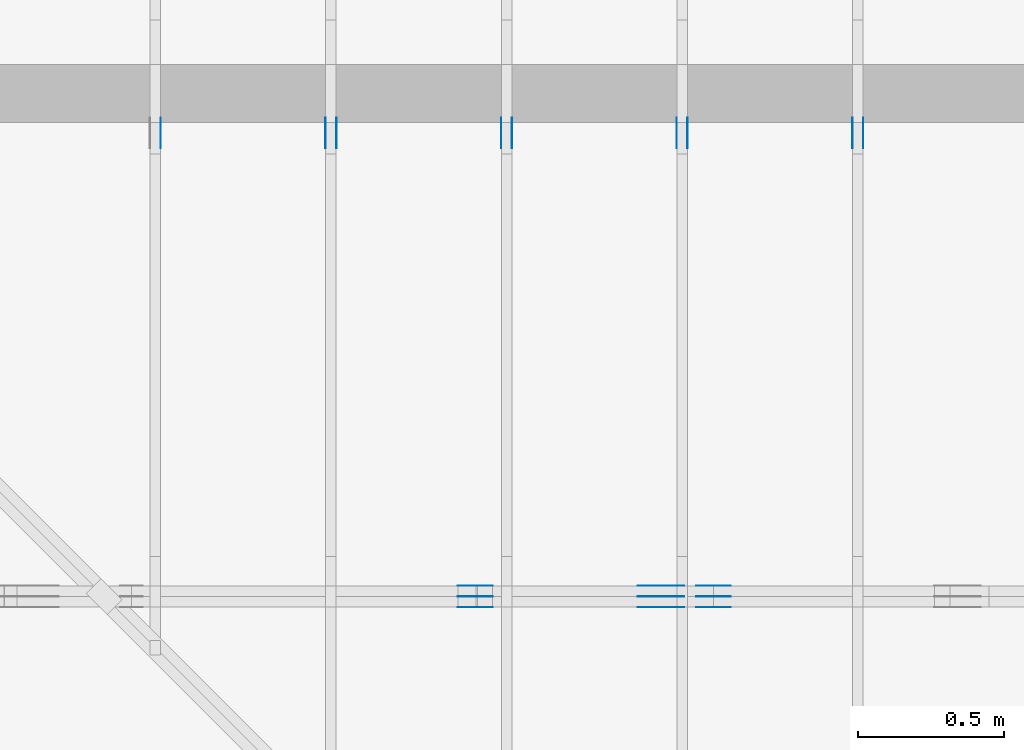
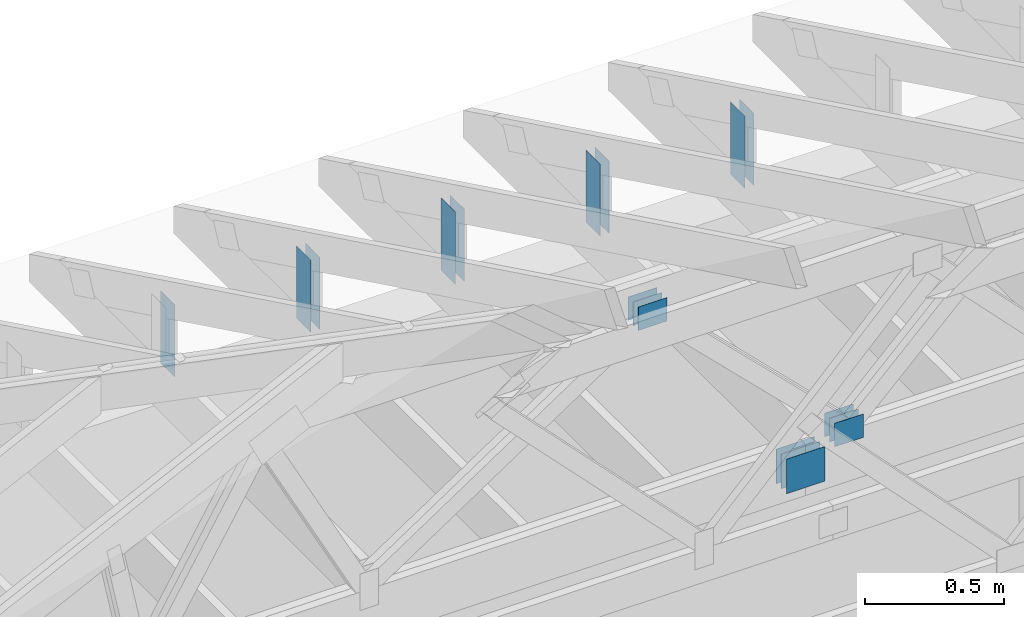
# One storey, part 110 of 159: 21 plates, 6 elements without a shape of their own.
"""IFC2X3 building model written with IfcOpenShell, lengths in millimetres."""

from ifc_helpers import new_model, si_unit, frame, origin, origin_with_axes, origin_2d, place, context, project, spatial, faceted_brep, element, aggregate, save


model = new_model("IFC2X3")

# Units and contexts
model_context = context("Model", 3, precision=1e-05, world=origin())
plan_context = context("Plan", 2, precision=1e-05, world=origin_2d())
ifc_project = project(units=[si_unit("LENGTHUNIT", "METRE", prefix="MILLI"), si_unit("AREAUNIT", "SQUARE_METRE"), si_unit("VOLUMEUNIT", "CUBIC_METRE"), si_unit("SOLIDANGLEUNIT", "STERADIAN"), si_unit("PLANEANGLEUNIT", "RADIAN"), si_unit("MASSUNIT", "GRAM"), si_unit("TIMEUNIT", "SECOND"), si_unit("THERMODYNAMICTEMPERATUREUNIT", "DEGREE_CELSIUS"), si_unit("LUMINOUSINTENSITYUNIT", "LUMEN")], contexts=[model_context, plan_context])

# Site, building, storey
site_placement = place(None, origin_with_axes())
site = spatial("IfcSite", under=ifc_project, at=site_placement, CompositionType="ELEMENT")
building_placement = place(site_placement, origin_with_axes())
building = spatial("IfcBuilding", under=site, at=building_placement, Name="Plan 1", CompositionType="ELEMENT")
storey_placement = place(building_placement, origin_with_axes())
storey = spatial("IfcBuildingStorey", under=building, at=storey_placement, Name="Etasje 1", CompositionType="ELEMENT", Elevation=0.0)

# Assembly, plates
assembly_1_placement = place(storey_placement, frame((19200.01266310149, 11417.999978540158, 0.0), z_axis=(1.2246063538223773e-16, 1.0, 6.123031769111886e-17), x_axis=(-1.0, 1.2246063538223773e-16, 0.0)))
assembly_1 = element("IfcElementAssembly", 1, at=assembly_1_placement, inside=storey, Name="V9 (1)", AssemblyPlace="FACTORY", PredefinedType="TRUSS")
plate_1_placement = place(assembly_1_placement, frame((5473.56888521173, 1069.3871058922014, 0.0), z_axis=(0.0, 0.0, 1.0), x_axis=(-1.0, 1.2246063538223773e-16, 0.0)))
plate_1 = element("IfcPlate", 2, at=plate_1_placement, Name="GNT100S 103x119", context=model_context, shape_type="Brep", body=[
    faceted_brep([(119.00003755548005, 103.00002093126386, 1.0), (3.755548004846787e-05, 103.00002093126386, 1.0), (3.755548004846787e-05, 2.093126386171207e-05, 1.0), (119.00003755548005, 2.093126386171207e-05, 1.0), (3.755548004846787e-05, 103.00002093126386, 4.5990679488203275e-21), (119.00003755548005, 103.00002093126386, 1.4572820209554237e-14), (119.00003755548005, 2.093126386171207e-05, 1.4572820209554237e-14), (3.755548004846787e-05, 2.093126386171207e-05, 4.5990679488203275e-21), (119.0, -2.1859223415729434e-14, 1.3384471942262577e-30), (119.0, -2.1797993098038315e-14, 1.0), (1.1247455413666031e-32, 6.123031769111886e-17, 1.0), (0.0, 0.0, 0.0), (119.0, 103.0, 0.0), (119.0, 103.0, 1.0), (119.0, 0.0, 1.0), (119.0, 0.0, 0.0), (0.0, 103.0, 0.0), (-3.7491518045553436e-33, 103.0, 1.0), (119.0, 102.99999999999999, 1.0), (119.0, 102.99999999999999, -7.888609052210118e-31), (0.0, 0.0, 0.0), (6.123031769111886e-17, -7.498303609110687e-33, 1.0), (1.2674675762061605e-14, 103.0, 1.0), (1.2613445444370486e-14, 103.0, -7.723252717384008e-31)], [[[0, 1, 2, 3]], [[4, 5, 6, 7]], [[8, 9, 10, 11]], [[12, 13, 14, 15]], [[16, 17, 18, 19]], [[20, 21, 22, 23]]]),
])
plate_2_placement = place(assembly_1_placement, frame((5473.56888521173, 1069.3871058922014, -37.0), z_axis=(0.0, 0.0, 1.0), x_axis=(-1.0, 1.2246063538223773e-16, 0.0)))
plate_2 = element("IfcPlate", 3, at=plate_2_placement, Name="GNT100S 103x119", context=model_context, shape_type="Brep", body=[
    faceted_brep([(119.00003755548005, 103.00002093126386, 1.0), (3.755548004846787e-05, 103.00002093126386, 1.0), (3.755548004846787e-05, 2.093126386171207e-05, 1.0), (119.00003755548005, 2.093126386171207e-05, 1.0), (3.755548004846787e-05, 103.00002093126386, 4.5990679488203275e-21), (119.00003755548005, 103.00002093126386, 1.4572820209554237e-14), (119.00003755548005, 2.093126386171207e-05, 1.4572820209554237e-14), (3.755548004846787e-05, 2.093126386171207e-05, 4.5990679488203275e-21), (119.0, -2.1859223415729434e-14, 1.3384471942262577e-30), (119.0, -2.1797993098038315e-14, 1.0), (1.1247455413666031e-32, 6.123031769111886e-17, 1.0), (0.0, 0.0, 0.0), (119.0, 103.0, 0.0), (119.0, 103.0, 1.0), (119.0, 0.0, 1.0), (119.0, 0.0, 0.0), (0.0, 103.0, 0.0), (-3.7491518045553436e-33, 103.0, 1.0), (119.0, 102.99999999999999, 1.0), (119.0, 102.99999999999999, -7.888609052210118e-31), (0.0, 0.0, 0.0), (6.123031769111886e-17, -7.498303609110687e-33, 1.0), (1.2674675762061605e-14, 103.0, 1.0), (1.2613445444370486e-14, 103.0, -7.723252717384008e-31)], [[[0, 1, 2, 3]], [[4, 5, 6, 7]], [[8, 9, 10, 11]], [[12, 13, 14, 15]], [[16, 17, 18, 19]], [[20, 21, 22, 23]]]),
])
plate_3_placement = place(assembly_1_placement, frame((5473.56888521173, 1069.3871058922014, -36.0), z_axis=(0.0, 0.0, 1.0), x_axis=(-1.0, 1.2246063538223773e-16, 0.0)))
plate_3 = element("IfcPlate", 4, at=plate_3_placement, Name="GNT100S 103x119", context=model_context, shape_type="Brep", body=[
    faceted_brep([(119.00003755548005, 103.00002093126386, 1.0), (3.755548004846787e-05, 103.00002093126386, 1.0), (3.755548004846787e-05, 2.093126386171207e-05, 1.0), (119.00003755548005, 2.093126386171207e-05, 1.0), (3.755548004846787e-05, 103.00002093126386, 4.5990679488203275e-21), (119.00003755548005, 103.00002093126386, 1.4572820209554237e-14), (119.00003755548005, 2.093126386171207e-05, 1.4572820209554237e-14), (3.755548004846787e-05, 2.093126386171207e-05, 4.5990679488203275e-21), (119.0, -2.1859223415729434e-14, 1.3384471942262577e-30), (119.0, -2.1797993098038315e-14, 1.0), (1.1247455413666031e-32, 6.123031769111886e-17, 1.0), (0.0, 0.0, 0.0), (119.0, 103.0, 0.0), (119.0, 103.0, 1.0), (119.0, 0.0, 1.0), (119.0, 0.0, 0.0), (0.0, 103.0, 0.0), (-3.7491518045553436e-33, 103.0, 1.0), (119.0, 102.99999999999999, 1.0), (119.0, 102.99999999999999, -7.888609052210118e-31), (0.0, 0.0, 0.0), (6.123031769111886e-17, -7.498303609110687e-33, 1.0), (1.2674675762061605e-14, 103.0, 1.0), (1.2613445444370486e-14, 103.0, -7.723252717384008e-31)], [[[0, 1, 2, 3]], [[4, 5, 6, 7]], [[8, 9, 10, 11]], [[12, 13, 14, 15]], [[16, 17, 18, 19]], [[20, 21, 22, 23]]]),
])
plate_4_placement = place(assembly_1_placement, frame((5473.56888521173, 1069.3871058922014, -73.0), z_axis=(0.0, 0.0, 1.0), x_axis=(-1.0, 1.2246063538223773e-16, 0.0)))
plate_4 = element("IfcPlate", 5, at=plate_4_placement, Name="GNT100S 103x119", context=model_context, shape_type="Brep", body=[
    faceted_brep([(119.00003755548005, 103.00002093126386, 1.0), (3.755548004846787e-05, 103.00002093126386, 1.0), (3.755548004846787e-05, 2.093126386171207e-05, 1.0), (119.00003755548005, 2.093126386171207e-05, 1.0), (3.755548004846787e-05, 103.00002093126386, 4.5990679488203275e-21), (119.00003755548005, 103.00002093126386, 1.4572820209554237e-14), (119.00003755548005, 2.093126386171207e-05, 1.4572820209554237e-14), (3.755548004846787e-05, 2.093126386171207e-05, 4.5990679488203275e-21), (119.0, -2.1859223415729434e-14, 1.3384471942262577e-30), (119.0, -2.1797993098038315e-14, 1.0), (1.1247455413666031e-32, 6.123031769111886e-17, 1.0), (0.0, 0.0, 0.0), (119.0, 103.0, 0.0), (119.0, 103.0, 1.0), (119.0, 0.0, 1.0), (119.0, 0.0, 0.0), (0.0, 103.0, 0.0), (-3.7491518045553436e-33, 103.0, 1.0), (119.0, 102.99999999999999, 1.0), (119.0, 102.99999999999999, -7.888609052210118e-31), (0.0, 0.0, 0.0), (6.123031769111886e-17, -7.498303609110687e-33, 1.0), (1.2674675762061605e-14, 103.0, 1.0), (1.2613445444370486e-14, 103.0, -7.723252717384008e-31)], [[[0, 1, 2, 3]], [[4, 5, 6, 7]], [[8, 9, 10, 11]], [[12, 13, 14, 15]], [[16, 17, 18, 19]], [[20, 21, 22, 23]]]),
])
plate_5_placement = place(assembly_1_placement, frame((4859.5, 187.50000000000034, 0.0), z_axis=(0.0, 0.0, 1.0), x_axis=(-1.0, 1.2246063538223773e-16, 0.0)))
plate_5 = element("IfcPlate", 6, at=plate_5_placement, Name="GNT100S 152x159", context=model_context, shape_type="Brep", body=[
    faceted_brep([(159.0, 152.00000000000034, 1.0), (0.0, 152.00000000000034, 1.0), (0.0, 3.410605131648481e-13, 1.0), (159.0, 3.410605131648481e-13, 1.0), (0.0, 152.00000000000034, 0.0), (159.0, 152.00000000000034, 1.9471241025775798e-14), (159.0, 3.694822225952521e-13, 1.9471241025775798e-14), (0.0, 3.694822225952521e-13, 0.0), (159.0, -2.92068615386637e-14, 1.788345410772899e-30), (159.0, -2.914563122097258e-14, 1.0), (1.1247455413666031e-32, 6.123031769111886e-17, 1.0), (0.0, 0.0, 0.0), (159.0, 152.0, 0.0), (159.0, 152.0, 1.0), (159.0, 0.0, 1.0), (159.0, 0.0, 0.0), (0.0, 152.0, 0.0), (-3.7491518045553436e-33, 152.0, 1.0), (159.0, 152.0, 1.0), (159.0, 152.0, 0.0), (0.0, 0.0, 0.0), (6.123031769111886e-17, -7.498303609110687e-33, 1.0), (1.8675246895791253e-14, 152.0, 1.0), (1.8614016578100134e-14, 152.0, -1.1397421485848245e-30)], [[[0, 1, 2, 3]], [[4, 5, 6, 7]], [[8, 9, 10, 11]], [[12, 13, 14, 15]], [[16, 17, 18, 19]], [[20, 21, 22, 23]]]),
])
plate_6_placement = place(assembly_1_placement, frame((4859.5, 187.50000000000034, -37.0), z_axis=(0.0, 0.0, 1.0), x_axis=(-1.0, 1.2246063538223773e-16, 0.0)))
plate_6 = element("IfcPlate", 7, at=plate_6_placement, Name="GNT100S 152x159", context=model_context, shape_type="Brep", body=[
    faceted_brep([(159.0, 152.00000000000034, 1.0), (0.0, 152.00000000000034, 1.0), (0.0, 3.410605131648481e-13, 1.0), (159.0, 3.410605131648481e-13, 1.0), (0.0, 152.00000000000034, 0.0), (159.0, 152.00000000000034, 1.9471241025775798e-14), (159.0, 3.694822225952521e-13, 1.9471241025775798e-14), (0.0, 3.694822225952521e-13, 0.0), (159.0, -2.92068615386637e-14, 1.788345410772899e-30), (159.0, -2.914563122097258e-14, 1.0), (1.1247455413666031e-32, 6.123031769111886e-17, 1.0), (0.0, 0.0, 0.0), (159.0, 152.0, 0.0), (159.0, 152.0, 1.0), (159.0, 0.0, 1.0), (159.0, 0.0, 0.0), (0.0, 152.0, 0.0), (-3.7491518045553436e-33, 152.0, 1.0), (159.0, 152.0, 1.0), (159.0, 152.0, 0.0), (0.0, 0.0, 0.0), (6.123031769111886e-17, -7.498303609110687e-33, 1.0), (1.8675246895791253e-14, 152.0, 1.0), (1.8614016578100134e-14, 152.0, -1.1397421485848245e-30)], [[[0, 1, 2, 3]], [[4, 5, 6, 7]], [[8, 9, 10, 11]], [[12, 13, 14, 15]], [[16, 17, 18, 19]], [[20, 21, 22, 23]]]),
])
plate_7_placement = place(assembly_1_placement, frame((4859.5, 187.50000000000034, -36.0), z_axis=(0.0, 0.0, 1.0), x_axis=(-1.0, 1.2246063538223773e-16, 0.0)))
plate_7 = element("IfcPlate", 8, at=plate_7_placement, Name="GNT100S 152x159", context=model_context, shape_type="Brep", body=[
    faceted_brep([(159.0, 152.00000000000034, 1.0), (0.0, 152.00000000000034, 1.0), (0.0, 3.410605131648481e-13, 1.0), (159.0, 3.410605131648481e-13, 1.0), (0.0, 152.00000000000034, 0.0), (159.0, 152.00000000000034, 1.9471241025775798e-14), (159.0, 3.694822225952521e-13, 1.9471241025775798e-14), (0.0, 3.694822225952521e-13, 0.0), (159.0, -2.92068615386637e-14, 1.788345410772899e-30), (159.0, -2.914563122097258e-14, 1.0), (1.1247455413666031e-32, 6.123031769111886e-17, 1.0), (0.0, 0.0, 0.0), (159.0, 152.0, 0.0), (159.0, 152.0, 1.0), (159.0, 0.0, 1.0), (159.0, 0.0, 0.0), (0.0, 152.0, 0.0), (-3.7491518045553436e-33, 152.0, 1.0), (159.0, 152.0, 1.0), (159.0, 152.0, 0.0), (0.0, 0.0, 0.0), (6.123031769111886e-17, -7.498303609110687e-33, 1.0), (1.8675246895791253e-14, 152.0, 1.0), (1.8614016578100134e-14, 152.0, -1.1397421485848245e-30)], [[[0, 1, 2, 3]], [[4, 5, 6, 7]], [[8, 9, 10, 11]], [[12, 13, 14, 15]], [[16, 17, 18, 19]], [[20, 21, 22, 23]]]),
])
plate_8_placement = place(assembly_1_placement, frame((4859.5, 187.50000000000034, -73.0), z_axis=(0.0, 0.0, 1.0), x_axis=(-1.0, 1.2246063538223773e-16, 0.0)))
plate_8 = element("IfcPlate", 9, at=plate_8_placement, Name="GNT100S 152x159", context=model_context, shape_type="Brep", body=[
    faceted_brep([(159.0, 152.00000000000034, 1.0), (0.0, 152.00000000000034, 1.0), (0.0, 3.410605131648481e-13, 1.0), (159.0, 3.410605131648481e-13, 1.0), (0.0, 152.00000000000034, 0.0), (159.0, 152.00000000000034, 1.9471241025775798e-14), (159.0, 3.694822225952521e-13, 1.9471241025775798e-14), (0.0, 3.694822225952521e-13, 0.0), (159.0, -2.92068615386637e-14, 1.788345410772899e-30), (159.0, -2.914563122097258e-14, 1.0), (1.1247455413666031e-32, 6.123031769111886e-17, 1.0), (0.0, 0.0, 0.0), (159.0, 152.0, 0.0), (159.0, 152.0, 1.0), (159.0, 0.0, 1.0), (159.0, 0.0, 0.0), (0.0, 152.0, 0.0), (-3.7491518045553436e-33, 152.0, 1.0), (159.0, 152.0, 1.0), (159.0, 152.0, 0.0), (0.0, 0.0, 0.0), (6.123031769111886e-17, -7.498303609110687e-33, 1.0), (1.8675246895791253e-14, 152.0, 1.0), (1.8614016578100134e-14, 152.0, -1.1397421485848245e-30)], [[[0, 1, 2, 3]], [[4, 5, 6, 7]], [[8, 9, 10, 11]], [[12, 13, 14, 15]], [[16, 17, 18, 19]], [[20, 21, 22, 23]]]),
])
plate_9_placement = place(assembly_1_placement, frame((4540.5, 171.5, 0.0), z_axis=(0.0, 0.0, 1.0), x_axis=(1.0, 0.0, 0.0)))
plate_9 = element("IfcPlate", 10, at=plate_9_placement, Name="GNT100S 103x119", context=model_context, shape_type="Brep", body=[
    faceted_brep([(119.0, 103.0, 1.0), (0.0, 103.0, 1.0), (0.0, 0.0, 1.0), (119.0, 0.0, 1.0), (0.0, 103.0, 0.0), (119.0, 103.0, 1.457281561048629e-14), (119.0, 0.0, 1.457281561048629e-14), (0.0, 0.0, 0.0), (119.00000000054115, 3.1920128974901925e-13, 1.3384471942323449e-30), (119.00000000054115, 3.1926252006671036e-13, 1.0), (5.411493475548923e-10, 3.411217434824398e-13, 1.0), (5.411493475548923e-10, 3.410605131647487e-13, 6.087240529027005e-42), (119.00000000054115, 103.00000000000034, 0.0), (119.00000000054115, 103.00000000000034, 1.0), (119.00000000054115, 3.410605131648481e-13, 1.0), (119.00000000054115, 3.410605131648481e-13, 0.0), (5.411493475548923e-10, 103.00000000000034, 0.0), (5.411493475548923e-10, 103.00000000000034, 1.0), (119.00000000054115, 103.00000000000033, 1.0), (119.00000000054115, 103.00000000000033, -7.888609052210118e-31), (5.411493475548923e-10, 3.410605131648481e-13, 0.0), (5.4114940878521e-10, 3.410605131648481e-13, 1.0), (5.411620222306544e-10, 103.00000000000034, 1.0), (5.411619610003367e-10, 103.00000000000034, -7.723252717384008e-31)], [[[0, 1, 2, 3]], [[4, 5, 6, 7]], [[8, 9, 10, 11]], [[12, 13, 14, 15]], [[16, 17, 18, 19]], [[20, 21, 22, 23]]]),
])
plate_10_placement = place(assembly_1_placement, frame((4540.5, 171.5, -37.0), z_axis=(0.0, 0.0, 1.0), x_axis=(1.0, 0.0, 0.0)))
plate_10 = element("IfcPlate", 11, at=plate_10_placement, Name="GNT100S 103x119", context=model_context, shape_type="Brep", body=[
    faceted_brep([(119.0, 103.0, 1.0), (0.0, 103.0, 1.0), (0.0, 0.0, 1.0), (119.0, 0.0, 1.0), (0.0, 103.0, 0.0), (119.0, 103.0, 1.457281561048629e-14), (119.0, 0.0, 1.457281561048629e-14), (0.0, 0.0, 0.0), (119.00000000054115, 3.1920128974901925e-13, 1.3384471942323449e-30), (119.00000000054115, 3.1926252006671036e-13, 1.0), (5.411493475548923e-10, 3.411217434824398e-13, 1.0), (5.411493475548923e-10, 3.410605131647487e-13, 6.087240529027005e-42), (119.00000000054115, 103.00000000000034, 0.0), (119.00000000054115, 103.00000000000034, 1.0), (119.00000000054115, 3.410605131648481e-13, 1.0), (119.00000000054115, 3.410605131648481e-13, 0.0), (5.411493475548923e-10, 103.00000000000034, 0.0), (5.411493475548923e-10, 103.00000000000034, 1.0), (119.00000000054115, 103.00000000000033, 1.0), (119.00000000054115, 103.00000000000033, -7.888609052210118e-31), (5.411493475548923e-10, 3.410605131648481e-13, 0.0), (5.4114940878521e-10, 3.410605131648481e-13, 1.0), (5.411620222306544e-10, 103.00000000000034, 1.0), (5.411619610003367e-10, 103.00000000000034, -7.723252717384008e-31)], [[[0, 1, 2, 3]], [[4, 5, 6, 7]], [[8, 9, 10, 11]], [[12, 13, 14, 15]], [[16, 17, 18, 19]], [[20, 21, 22, 23]]]),
])
plate_11_placement = place(assembly_1_placement, frame((4540.5, 171.5, -36.0), z_axis=(0.0, 0.0, 1.0), x_axis=(1.0, 0.0, 0.0)))
plate_11 = element("IfcPlate", 12, at=plate_11_placement, Name="GNT100S 103x119", context=model_context, shape_type="Brep", body=[
    faceted_brep([(119.0, 103.0, 1.0), (0.0, 103.0, 1.0), (0.0, 0.0, 1.0), (119.0, 0.0, 1.0), (0.0, 103.0, 0.0), (119.0, 103.0, 1.457281561048629e-14), (119.0, 0.0, 1.457281561048629e-14), (0.0, 0.0, 0.0), (119.00000000054115, 3.1920128974901925e-13, 1.3384471942323449e-30), (119.00000000054115, 3.1926252006671036e-13, 1.0), (5.411493475548923e-10, 3.411217434824398e-13, 1.0), (5.411493475548923e-10, 3.410605131647487e-13, 6.087240529027005e-42), (119.00000000054115, 103.00000000000034, 0.0), (119.00000000054115, 103.00000000000034, 1.0), (119.00000000054115, 3.410605131648481e-13, 1.0), (119.00000000054115, 3.410605131648481e-13, 0.0), (5.411493475548923e-10, 103.00000000000034, 0.0), (5.411493475548923e-10, 103.00000000000034, 1.0), (119.00000000054115, 103.00000000000033, 1.0), (119.00000000054115, 103.00000000000033, -7.888609052210118e-31), (5.411493475548923e-10, 3.410605131648481e-13, 0.0), (5.4114940878521e-10, 3.410605131648481e-13, 1.0), (5.411620222306544e-10, 103.00000000000034, 1.0), (5.411619610003367e-10, 103.00000000000034, -7.723252717384008e-31)], [[[0, 1, 2, 3]], [[4, 5, 6, 7]], [[8, 9, 10, 11]], [[12, 13, 14, 15]], [[16, 17, 18, 19]], [[20, 21, 22, 23]]]),
])
plate_12_placement = place(assembly_1_placement, frame((4540.5, 171.5, -73.0), z_axis=(0.0, 0.0, 1.0), x_axis=(1.0, 0.0, 0.0)))
plate_12 = element("IfcPlate", 13, at=plate_12_placement, Name="GNT100S 103x119", context=model_context, shape_type="Brep", body=[
    faceted_brep([(119.0, 103.0, 1.0), (0.0, 103.0, 1.0), (0.0, 0.0, 1.0), (119.0, 0.0, 1.0), (0.0, 103.0, 0.0), (119.0, 103.0, 1.457281561048629e-14), (119.0, 0.0, 1.457281561048629e-14), (0.0, 0.0, 0.0), (119.00000000054115, 3.1920128974901925e-13, 1.3384471942323449e-30), (119.00000000054115, 3.1926252006671036e-13, 1.0), (5.411493475548923e-10, 3.411217434824398e-13, 1.0), (5.411493475548923e-10, 3.410605131647487e-13, 6.087240529027005e-42), (119.00000000054115, 103.00000000000034, 0.0), (119.00000000054115, 103.00000000000034, 1.0), (119.00000000054115, 3.410605131648481e-13, 1.0), (119.00000000054115, 3.410605131648481e-13, 0.0), (5.411493475548923e-10, 103.00000000000034, 0.0), (5.411493475548923e-10, 103.00000000000034, 1.0), (119.00000000054115, 103.00000000000033, 1.0), (119.00000000054115, 103.00000000000033, -7.888609052210118e-31), (5.411493475548923e-10, 3.410605131648481e-13, 0.0), (5.4114940878521e-10, 3.410605131648481e-13, 1.0), (5.411620222306544e-10, 103.00000000000034, 1.0), (5.411619610003367e-10, 103.00000000000034, -7.723252717384008e-31)], [[[0, 1, 2, 3]], [[4, 5, 6, 7]], [[8, 9, 10, 11]], [[12, 13, 14, 15]], [[16, 17, 18, 19]], [[20, 21, 22, 23]]]),
])
aggregate(assembly_1, [plate_1, plate_2, plate_3, plate_4, plate_5, plate_6, plate_7, plate_8, plate_9, plate_10, plate_11, plate_12])

assembly_2_placement = place(storey_placement, frame((15075.022261404756, 13899.999978540158, 1.1021457184401395e-15), z_axis=(-1.0, 1.836909530733566e-16, 6.123031769111886e-17), x_axis=(-1.836909530733566e-16, -1.0, 0.0)))
assembly_2 = element("IfcElementAssembly", 14, at=assembly_2_placement, inside=storey, Name="S37 (66)", AssemblyPlace="FACTORY", PredefinedType="TRUSS")
plate_13_placement = place(assembly_2_placement, frame((986.0125131977218, 165.43966674804688, 0.0), z_axis=(0.0, 0.0, 1.0), x_axis=(6.123031769111886e-17, 1.0, 0.0)))
plate_13 = element("IfcPlate", 15, at=plate_13_placement, Name="GNT100S 103x317", context=model_context, shape_type="Brep", body=[
    faceted_brep([(317.0, 103.00000099069052, 1.0), (0.0, 103.00000099069052, 1.0), (0.0, 9.906905233947327e-07, 1.0), (317.0, 9.906905233947327e-07, 1.0), (0.0, 103.00000099069052, 0.0), (317.0, 103.00000099069052, 3.882002141616936e-14), (317.0, 9.906905233947327e-07, 3.882002141616936e-14), (0.0, 9.906905233947327e-07, 0.0), (317.0000058635244, -5.823003320133043e-14, 3.565443432081861e-30), (317.0000058635244, -5.816880288363931e-14, 1.0), (5.863524393134867e-06, 6.122924061473473e-17, 1.0), (5.863524393134867e-06, -1.0770763841438185e-21, 6.594972917872759e-38), (317.0000058635244, 103.0, 0.0), (317.0000058635244, 103.0, 1.0), (317.0000058635244, 0.0, 1.0), (317.0000058635244, 0.0, 0.0), (5.863524393134867e-06, 103.0, 0.0), (5.863524393134867e-06, 103.0, 1.0), (317.0000058635244, 102.99999999999999, 1.0), (317.0000058635244, 102.99999999999999, -1.5777218104420236e-30), (5.863524393134867e-06, 0.0, 0.0), (5.863524393196097e-06, -7.498303609110687e-33, 1.0), (5.863524405809543e-06, 103.0, 1.0), (5.863524405748312e-06, 103.0, -7.723252732077687e-31)], [[[0, 1, 2, 3]], [[4, 5, 6, 7]], [[8, 9, 10, 11]], [[12, 13, 14, 15]], [[16, 17, 18, 19]], [[20, 21, 22, 23]]]),
])
plate_14_placement = place(assembly_2_placement, frame((986.0125131977218, 165.43966674804688, -37.0), z_axis=(0.0, 0.0, 1.0), x_axis=(6.123031769111886e-17, 1.0, 0.0)))
plate_14 = element("IfcPlate", 16, at=plate_14_placement, Name="GNT100S 103x317", context=model_context, shape_type="Brep", body=[
    faceted_brep([(317.0, 103.00000099069052, 1.0), (0.0, 103.00000099069052, 1.0), (0.0, 9.906905233947327e-07, 1.0), (317.0, 9.906905233947327e-07, 1.0), (0.0, 103.00000099069052, 0.0), (317.0, 103.00000099069052, 3.882002141616936e-14), (317.0, 9.906905233947327e-07, 3.882002141616936e-14), (0.0, 9.906905233947327e-07, 0.0), (317.0000058635244, -5.823003320133043e-14, 3.565443432081861e-30), (317.0000058635244, -5.816880288363931e-14, 1.0), (5.863524393134867e-06, 6.122924061473473e-17, 1.0), (5.863524393134867e-06, -1.0770763841438185e-21, 6.594972917872759e-38), (317.0000058635244, 103.0, 0.0), (317.0000058635244, 103.0, 1.0), (317.0000058635244, 0.0, 1.0), (317.0000058635244, 0.0, 0.0), (5.863524393134867e-06, 103.0, 0.0), (5.863524393134867e-06, 103.0, 1.0), (317.0000058635244, 102.99999999999999, 1.0), (317.0000058635244, 102.99999999999999, -1.5777218104420236e-30), (5.863524393134867e-06, 0.0, 0.0), (5.863524393196097e-06, -7.498303609110687e-33, 1.0), (5.863524405809543e-06, 103.0, 1.0), (5.863524405748312e-06, 103.0, -7.723252732077687e-31)], [[[0, 1, 2, 3]], [[4, 5, 6, 7]], [[8, 9, 10, 11]], [[12, 13, 14, 15]], [[16, 17, 18, 19]], [[20, 21, 22, 23]]]),
])
aggregate(assembly_2, [plate_13, plate_14])

assembly_3_placement = place(storey_placement, frame((14475.022261404756, 13899.999978540158, 1.1021457184401395e-15), z_axis=(-1.0, 1.836909530733566e-16, 6.123031769111886e-17), x_axis=(-1.836909530733566e-16, -1.0, 0.0)))
assembly_3 = element("IfcElementAssembly", 17, at=assembly_3_placement, inside=storey, Name="S36 (68)", AssemblyPlace="FACTORY", PredefinedType="TRUSS")
plate_15_placement = place(assembly_3_placement, frame((986.0125131977466, 165.43966674804688, 0.0), z_axis=(0.0, 0.0, 1.0), x_axis=(6.123031769111886e-17, 1.0, 0.0)))
plate_15 = element("IfcPlate", 18, at=plate_15_placement, Name="GNT100S 103x317", context=model_context, shape_type="Brep", body=[
    faceted_brep([(317.0, 103.00000099071531, 1.0), (0.0, 103.00000099071531, 1.0), (0.0, 9.90715307125356e-07, 1.0), (317.0, 9.90715307125356e-07, 1.0), (0.0, 103.00000099071531, 0.0), (317.0, 103.00000099071531, 3.882002141616936e-14), (317.0, 9.90715307125356e-07, 3.882002141616936e-14), (0.0, 9.90715307125356e-07, 0.0), (317.00000586346664, -5.823003320131981e-14, 3.5654434320812116e-30), (317.00000586346664, -5.816880288362869e-14, 1.0), (5.863466640221304e-06, 6.12292406253434e-17, 1.0), (5.863466640221304e-06, -1.0770657754560834e-21, 6.594907960540728e-38), (317.00000586346664, 103.0, 0.0), (317.00000586346664, 103.0, 1.0), (317.00000586346664, 0.0, 1.0), (317.00000586346664, 0.0, 0.0), (5.863466640221304e-06, 103.0, 0.0), (5.863466640221304e-06, 103.0, 1.0), (317.00000586346664, 102.99999999999999, 1.0), (317.00000586346664, 102.99999999999999, -1.5777218104420236e-30), (5.863466640221304e-06, 0.0, 0.0), (5.863466640282535e-06, -7.498303609110687e-33, 1.0), (5.86346665289598e-06, 103.0, 1.0), (5.86346665283475e-06, 103.0, -7.723252732077687e-31)], [[[0, 1, 2, 3]], [[4, 5, 6, 7]], [[8, 9, 10, 11]], [[12, 13, 14, 15]], [[16, 17, 18, 19]], [[20, 21, 22, 23]]]),
])
plate_16_placement = place(assembly_3_placement, frame((986.0125131977466, 165.43966674804688, -37.0), z_axis=(0.0, 0.0, 1.0), x_axis=(6.123031769111886e-17, 1.0, 0.0)))
plate_16 = element("IfcPlate", 19, at=plate_16_placement, Name="GNT100S 103x317", context=model_context, shape_type="Brep", body=[
    faceted_brep([(317.0, 103.00000099071531, 1.0), (0.0, 103.00000099071531, 1.0), (0.0, 9.90715307125356e-07, 1.0), (317.0, 9.90715307125356e-07, 1.0), (0.0, 103.00000099071531, 0.0), (317.0, 103.00000099071531, 3.882002141616936e-14), (317.0, 9.90715307125356e-07, 3.882002141616936e-14), (0.0, 9.90715307125356e-07, 0.0), (317.00000586346664, -5.823003320131981e-14, 3.5654434320812116e-30), (317.00000586346664, -5.816880288362869e-14, 1.0), (5.863466640221304e-06, 6.12292406253434e-17, 1.0), (5.863466640221304e-06, -1.0770657754560834e-21, 6.594907960540728e-38), (317.00000586346664, 103.0, 0.0), (317.00000586346664, 103.0, 1.0), (317.00000586346664, 0.0, 1.0), (317.00000586346664, 0.0, 0.0), (5.863466640221304e-06, 103.0, 0.0), (5.863466640221304e-06, 103.0, 1.0), (317.00000586346664, 102.99999999999999, 1.0), (317.00000586346664, 102.99999999999999, -1.5777218104420236e-30), (5.863466640221304e-06, 0.0, 0.0), (5.863466640282535e-06, -7.498303609110687e-33, 1.0), (5.86346665289598e-06, 103.0, 1.0), (5.86346665283475e-06, 103.0, -7.723252732077687e-31)], [[[0, 1, 2, 3]], [[4, 5, 6, 7]], [[8, 9, 10, 11]], [[12, 13, 14, 15]], [[16, 17, 18, 19]], [[20, 21, 22, 23]]]),
])
aggregate(assembly_3, [plate_15, plate_16])

# Assembly, plate
assembly_4_placement = place(storey_placement, frame((12675.022261404758, 13899.999978540158, 1.1021457184401395e-15), z_axis=(-1.0, 1.836909530733566e-16, 6.123031769111886e-17), x_axis=(-1.836909530733566e-16, -1.0, 0.0)))
assembly_4 = element("IfcElementAssembly", 20, at=assembly_4_placement, inside=storey, Name="S33 (69)", AssemblyPlace="FACTORY", PredefinedType="TRUSS")
plate_17_placement = place(assembly_4_placement, frame((986.0125131970744, 165.43966674804688, -37.0), z_axis=(0.0, 0.0, 1.0), x_axis=(6.123031769111886e-17, 1.0, 0.0)))
plate_17 = element("IfcPlate", 21, at=plate_17_placement, Name="GNT100S 103x317", context=model_context, shape_type="Brep", body=[
    faceted_brep([(317.0, 103.00000099004319, 1.0), (0.0, 103.00000099004319, 1.0), (0.0, 9.900431905407459e-07, 1.0), (317.0, 9.900431905407459e-07, 1.0), (0.0, 103.00000099004319, 0.0), (317.0, 103.00000099004319, 3.882002141616936e-14), (317.0, 9.900431905407459e-07, 3.882002141616936e-14), (0.0, 9.900431905407459e-07, 0.0), (317.0000058634071, -5.823003320130888e-14, 3.565443432080542e-30), (317.0000058634071, -5.816880288361776e-14, 1.0), (5.863407125161757e-06, 6.122924063627578e-17, 1.0), (5.863407125161757e-06, -1.077054843078073e-21, 6.594841021242858e-38), (317.0000058634071, 103.0, 0.0), (317.0000058634071, 103.0, 1.0), (317.0000058634071, 0.0, 1.0), (317.0000058634071, 0.0, 0.0), (5.863407125161757e-06, 103.0, 0.0), (5.863407125161757e-06, 103.0, 1.0), (317.0000058634071, 102.99999999999999, 1.0), (317.0000058634071, 102.99999999999999, -1.5777218104420236e-30), (5.863407125161757e-06, 0.0, 0.0), (5.863407125222987e-06, -7.498303609110687e-33, 1.0), (5.863407137836433e-06, 103.0, 1.0), (5.8634071377752024e-06, 103.0, -7.723252732077687e-31)], [[[0, 1, 2, 3]], [[4, 5, 6, 7]], [[8, 9, 10, 11]], [[12, 13, 14, 15]], [[16, 17, 18, 19]], [[20, 21, 22, 23]]]),
])
aggregate(assembly_4, [plate_17])

# Assembly, plates
assembly_5_placement = place(storey_placement, frame((13275.022261404756, 13899.999978540158, 1.1021457184401395e-15), z_axis=(-1.0, 1.836909530733566e-16, 6.123031769111886e-17), x_axis=(-1.836909530733566e-16, -1.0, 0.0)))
assembly_5 = element("IfcElementAssembly", 22, at=assembly_5_placement, inside=storey, Name="S34 (71)", AssemblyPlace="FACTORY", PredefinedType="TRUSS")
plate_18_placement = place(assembly_5_placement, frame((986.0125131973714, 165.43966674804688, 0.0), z_axis=(0.0, 0.0, 1.0), x_axis=(6.123031769111886e-17, 1.0, 0.0)))
plate_18 = element("IfcPlate", 23, at=plate_18_placement, Name="GNT100S 103x317", context=model_context, shape_type="Brep", body=[
    faceted_brep([(317.0, 103.00000099034014, 1.0), (0.0, 103.00000099034014, 1.0), (0.0, 9.903401405608747e-07, 1.0), (317.0, 9.903401405608747e-07, 1.0), (0.0, 103.00000099034014, 0.0), (317.0, 103.00000099034014, 3.882002141616936e-14), (317.0, 9.903401405608747e-07, 3.882002141616936e-14), (0.0, 9.903401405608747e-07, 0.0), (317.00000586341366, -5.823003320131008e-14, 3.565443432080615e-30), (317.00000586341366, -5.816880288361896e-14, 1.0), (5.863413662154926e-06, 6.1229240635075e-17, 1.0), (5.863413662154926e-06, -1.0770560438645784e-21, 6.594848373696779e-38), (317.00000586341366, 103.0, 0.0), (317.00000586341366, 103.0, 1.0), (317.00000586341366, 0.0, 1.0), (317.00000586341366, 0.0, 0.0), (5.863413662154926e-06, 103.0, 0.0), (5.863413662154926e-06, 103.0, 1.0), (317.00000586341366, 102.99999999999999, 1.0), (317.00000586341366, 102.99999999999999, -1.5777218104420236e-30), (5.863413662154926e-06, 0.0, 0.0), (5.863413662216156e-06, -7.498303609110687e-33, 1.0), (5.863413674829602e-06, 103.0, 1.0), (5.8634136747683714e-06, 103.0, -7.723252732077687e-31)], [[[0, 1, 2, 3]], [[4, 5, 6, 7]], [[8, 9, 10, 11]], [[12, 13, 14, 15]], [[16, 17, 18, 19]], [[20, 21, 22, 23]]]),
])
plate_19_placement = place(assembly_5_placement, frame((986.0125131973714, 165.43966674804688, -37.0), z_axis=(0.0, 0.0, 1.0), x_axis=(6.123031769111886e-17, 1.0, 0.0)))
plate_19 = element("IfcPlate", 24, at=plate_19_placement, Name="GNT100S 103x317", context=model_context, shape_type="Brep", body=[
    faceted_brep([(317.0, 103.00000099034014, 1.0), (0.0, 103.00000099034014, 1.0), (0.0, 9.903401405608747e-07, 1.0), (317.0, 9.903401405608747e-07, 1.0), (0.0, 103.00000099034014, 0.0), (317.0, 103.00000099034014, 3.882002141616936e-14), (317.0, 9.903401405608747e-07, 3.882002141616936e-14), (0.0, 9.903401405608747e-07, 0.0), (317.00000586341366, -5.823003320131008e-14, 3.565443432080615e-30), (317.00000586341366, -5.816880288361896e-14, 1.0), (5.863413662154926e-06, 6.1229240635075e-17, 1.0), (5.863413662154926e-06, -1.0770560438645784e-21, 6.594848373696779e-38), (317.00000586341366, 103.0, 0.0), (317.00000586341366, 103.0, 1.0), (317.00000586341366, 0.0, 1.0), (317.00000586341366, 0.0, 0.0), (5.863413662154926e-06, 103.0, 0.0), (5.863413662154926e-06, 103.0, 1.0), (317.00000586341366, 102.99999999999999, 1.0), (317.00000586341366, 102.99999999999999, -1.5777218104420236e-30), (5.863413662154926e-06, 0.0, 0.0), (5.863413662216156e-06, -7.498303609110687e-33, 1.0), (5.863413674829602e-06, 103.0, 1.0), (5.8634136747683714e-06, 103.0, -7.723252732077687e-31)], [[[0, 1, 2, 3]], [[4, 5, 6, 7]], [[8, 9, 10, 11]], [[12, 13, 14, 15]], [[16, 17, 18, 19]], [[20, 21, 22, 23]]]),
])
aggregate(assembly_5, [plate_18, plate_19])

assembly_6_placement = place(storey_placement, frame((13875.022261404758, 13899.999978540158, 1.1021457184401395e-15), z_axis=(-1.0, 1.836909530733566e-16, 6.123031769111886e-17), x_axis=(-1.836909530733566e-16, -1.0, 0.0)))
assembly_6 = element("IfcElementAssembly", 25, at=assembly_6_placement, inside=storey, Name="S35 (73)", AssemblyPlace="FACTORY", PredefinedType="TRUSS")
plate_20_placement = place(assembly_6_placement, frame((986.0125131975617, 165.43966674804688, 0.0), z_axis=(0.0, 0.0, 1.0), x_axis=(6.123031769111886e-17, 1.0, 0.0)))
plate_20 = element("IfcPlate", 26, at=plate_20_placement, Name="GNT100S 103x317", context=model_context, shape_type="Brep", body=[
    faceted_brep([(317.0, 103.00000099053045, 1.0), (0.0, 103.00000099053045, 1.0), (0.0, 9.905304523272207e-07, 1.0), (317.0, 9.905304523272207e-07, 1.0), (0.0, 103.00000099053045, 0.0), (317.0, 103.00000099053045, 3.882002141616936e-14), (317.0, 9.905304523272207e-07, 3.882002141616936e-14), (0.0, 9.905304523272207e-07, 0.0), (317.0000058634184, -5.823003320131095e-14, 3.5654434320806686e-30), (317.0000058634184, -5.816880288361983e-14, 1.0), (5.8634183801586914e-06, 6.122924063420835e-17, 1.0), (5.8634183801586914e-06, -1.0770569105191867e-21, 6.594853680250478e-38), (317.0000058634184, 103.0, 0.0), (317.0000058634184, 103.0, 1.0), (317.0000058634184, 0.0, 1.0), (317.0000058634184, 0.0, 0.0), (5.8634183801586914e-06, 103.0, 0.0), (5.8634183801586914e-06, 103.0, 1.0), (317.0000058634184, 102.99999999999999, 1.0), (317.0000058634184, 102.99999999999999, -1.5777218104420236e-30), (5.8634183801586914e-06, 0.0, 0.0), (5.863418380219922e-06, -7.498303609110687e-33, 1.0), (5.863418392833367e-06, 103.0, 1.0), (5.863418392772137e-06, 103.0, -7.723252732077687e-31)], [[[0, 1, 2, 3]], [[4, 5, 6, 7]], [[8, 9, 10, 11]], [[12, 13, 14, 15]], [[16, 17, 18, 19]], [[20, 21, 22, 23]]]),
])
plate_21_placement = place(assembly_6_placement, frame((986.0125131975617, 165.43966674804688, -37.0), z_axis=(0.0, 0.0, 1.0), x_axis=(6.123031769111886e-17, 1.0, 0.0)))
plate_21 = element("IfcPlate", 27, at=plate_21_placement, Name="GNT100S 103x317", context=model_context, shape_type="Brep", body=[
    faceted_brep([(317.0, 103.00000099053045, 1.0), (0.0, 103.00000099053045, 1.0), (0.0, 9.905304523272207e-07, 1.0), (317.0, 9.905304523272207e-07, 1.0), (0.0, 103.00000099053045, 0.0), (317.0, 103.00000099053045, 3.882002141616936e-14), (317.0, 9.905304523272207e-07, 3.882002141616936e-14), (0.0, 9.905304523272207e-07, 0.0), (317.0000058634184, -5.823003320131095e-14, 3.5654434320806686e-30), (317.0000058634184, -5.816880288361983e-14, 1.0), (5.8634183801586914e-06, 6.122924063420835e-17, 1.0), (5.8634183801586914e-06, -1.0770569105191867e-21, 6.594853680250478e-38), (317.0000058634184, 103.0, 0.0), (317.0000058634184, 103.0, 1.0), (317.0000058634184, 0.0, 1.0), (317.0000058634184, 0.0, 0.0), (5.8634183801586914e-06, 103.0, 0.0), (5.8634183801586914e-06, 103.0, 1.0), (317.0000058634184, 102.99999999999999, 1.0), (317.0000058634184, 102.99999999999999, -1.5777218104420236e-30), (5.8634183801586914e-06, 0.0, 0.0), (5.863418380219922e-06, -7.498303609110687e-33, 1.0), (5.863418392833367e-06, 103.0, 1.0), (5.863418392772137e-06, 103.0, -7.723252732077687e-31)], [[[0, 1, 2, 3]], [[4, 5, 6, 7]], [[8, 9, 10, 11]], [[12, 13, 14, 15]], [[16, 17, 18, 19]], [[20, 21, 22, 23]]]),
])
aggregate(assembly_6, [plate_20, plate_21])

save(model, "model.ifc")
